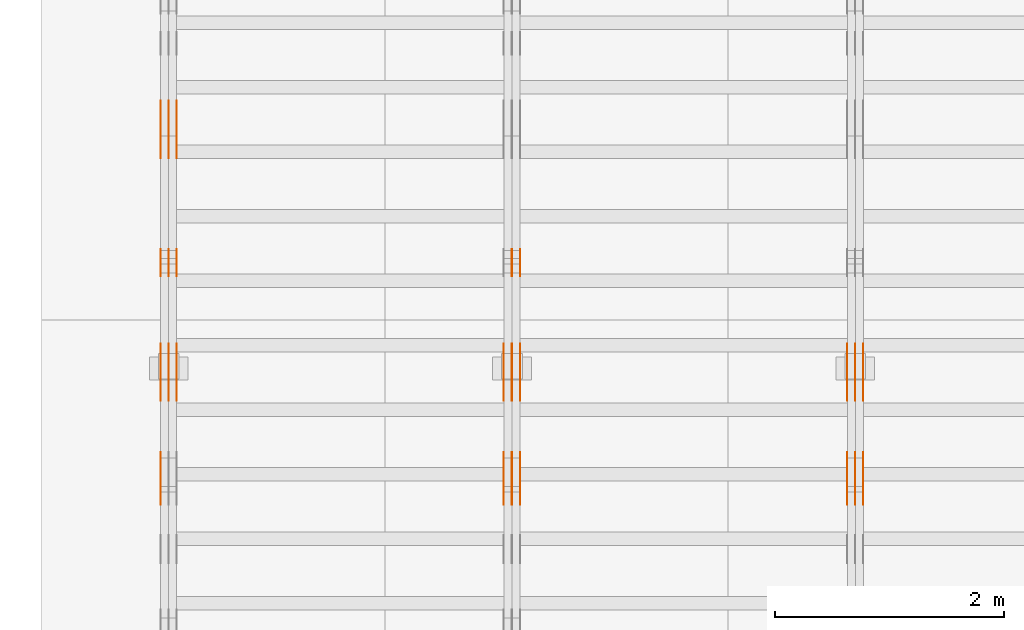
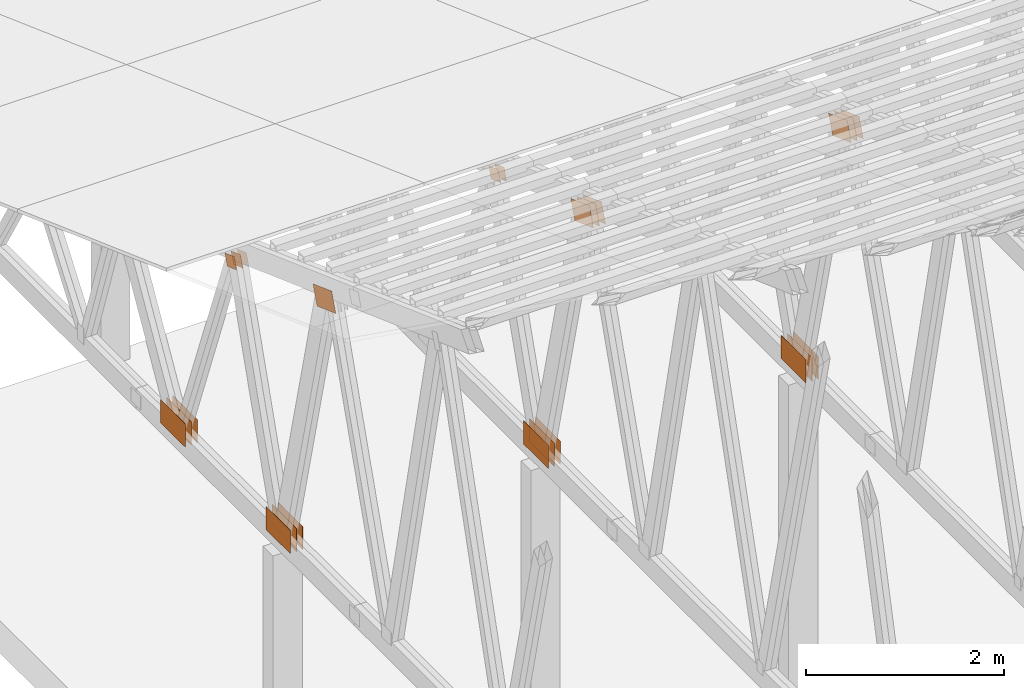
# One storey, part 107 of 189: 31 proxies.
"""IFC2X3 building model written with IfcOpenShell, lengths in millimetres."""

from ifc_helpers import new_model, entity, si_unit, converted_unit, derived_unit, direction, frame, origin, origin_2d_with_axis, place, context, subcontext, project, spatial, polyline, rectangle, outline, extrude, source, transform, mapped, material, type_object, type_shapes, element, save


model = new_model("IFC2X3")

# Units and contexts
model_context = context("Model", 3, precision=0.01, world=origin(), true_north=direction((6.12303176911189e-17, 1.0)))
body_context = subcontext(model_context, "Body", "Model", "MODEL_VIEW")
ifc_project = project(units=[si_unit("LENGTHUNIT", "METRE", prefix="MILLI"), si_unit("AREAUNIT", "SQUARE_METRE"), si_unit("VOLUMEUNIT", "CUBIC_METRE"), converted_unit("PLANEANGLEUNIT", "DEGREE", entity("IfcRatioMeasure", 0.0174532925199433), si_unit("PLANEANGLEUNIT", "RADIAN"), dimensions=[0, 0, 0, 0, 0, 0, 0]), si_unit("MASSUNIT", "GRAM", prefix="KILO"), derived_unit("MASSDENSITYUNIT", [(si_unit("MASSUNIT", "GRAM", prefix="KILO"), 1), (si_unit("LENGTHUNIT", "METRE"), -3)]), si_unit("TIMEUNIT", "SECOND"), si_unit("FREQUENCYUNIT", "HERTZ"), si_unit("THERMODYNAMICTEMPERATUREUNIT", "DEGREE_CELSIUS"), derived_unit("THERMALTRANSMITTANCEUNIT", [(si_unit("MASSUNIT", "GRAM", prefix="KILO"), 1), (si_unit("THERMODYNAMICTEMPERATUREUNIT", "KELVIN"), -1), (si_unit("TIMEUNIT", "SECOND"), -3)]), derived_unit("VOLUMETRICFLOWRATEUNIT", [(si_unit("LENGTHUNIT", "METRE"), 3), (si_unit("TIMEUNIT", "SECOND"), -1)]), si_unit("ELECTRICCURRENTUNIT", "AMPERE"), si_unit("ELECTRICVOLTAGEUNIT", "VOLT"), si_unit("POWERUNIT", "WATT"), si_unit("FORCEUNIT", "NEWTON"), si_unit("ILLUMINANCEUNIT", "LUX"), si_unit("LUMINOUSFLUXUNIT", "LUMEN"), si_unit("LUMINOUSINTENSITYUNIT", "CANDELA"), derived_unit("USERDEFINED", [(si_unit("MASSUNIT", "GRAM", prefix="KILO"), -1), (si_unit("LENGTHUNIT", "METRE"), -2), (si_unit("TIMEUNIT", "SECOND"), 3), (si_unit("LUMINOUSFLUXUNIT", "LUMEN"), 1)]), derived_unit("LINEARVELOCITYUNIT", [(si_unit("LENGTHUNIT", "METRE"), 1), (si_unit("TIMEUNIT", "SECOND"), -1)]), si_unit("PRESSUREUNIT", "PASCAL"), derived_unit("USERDEFINED", [(si_unit("LENGTHUNIT", "METRE"), -2), (si_unit("MASSUNIT", "GRAM", prefix="KILO"), 1), (si_unit("TIMEUNIT", "SECOND"), -2)])], contexts=[model_context])

# Site, building, storey
site_placement = place(None, origin())
site = spatial("IfcSite", under=ifc_project, at=site_placement, CompositionType="ELEMENT")
building_placement = place(site_placement, origin())
building = spatial("IfcBuilding", under=site, at=building_placement, CompositionType="ELEMENT")
storey_placement = place(building_placement, origin())
storey = spatial("IfcBuildingStorey", under=building, at=storey_placement, Name="Default", CompositionType="ELEMENT", Elevation=0.0)

# Proxies
ifc_material_1 = material(Name="IfcSurfaceStyle #44914")
building_element_proxy_type_1 = type_object("IfcBuildingElementProxyType", PredefinedType="NOTDEFINED", material=ifc_material_1)
shared_shape_1 = source(origin(), body_context, "Body", "SweptSolid", [
    extrude(outline(polyline([(-200.000344770935, -119.999765965113), (199.999582244654, -119.999765965113), (200.000344770935, 119.999765965113), (-199.999582244653, 119.999765965113), (-200.000344770935, -119.999765965113)])), frame((200.000344770935, 119.999990805307, 0.0), z_axis=(0.0, 0.0, 1.0), x_axis=(-1.0, 0.0, 0.0)), (0.0, 0.0, 1.0), 1.29999999999999),
])
type_shapes(building_element_proxy_type_1, [shared_shape_1])
proxy_1_placement = place(building_placement, frame((6336.3, 19620.1777846684, 3837.77137841443), z_axis=(-1.0, 0.0, 0.0), x_axis=(0.0, 0.939692620785908, -0.342020143325669)))
element("IfcBuildingElementProxy", 1, at=proxy_1_placement, inside=storey, type_object=building_element_proxy_type_1, material=ifc_material_1, context=body_context, shape_type="MappedRepresentation", body=[
    mapped(shared_shape_1, transform((0.0, 0.0, 0.0), scale=1.0)),
])
ifc_material_2 = material(Name="IfcSurfaceStyle #44857")
building_element_proxy_type_2 = type_object("IfcBuildingElementProxyType", PredefinedType="NOTDEFINED", material=ifc_material_2)
shared_shape_2 = source(origin(), body_context, "Body", "SweptSolid", [
    extrude(outline(polyline([(-200.000344770935, -119.999765965113), (199.999582244654, -119.999765965113), (200.000344770935, 119.999765965113), (-199.999582244653, 119.999765965113), (-200.000344770935, -119.999765965113)])), frame((200.000344770935, 119.999990805307, 0.0), z_axis=(0.0, 0.0, 1.0), x_axis=(-1.0, 0.0, 0.0)), (0.0, 0.0, 1.0), 1.29999999999997),
])
type_shapes(building_element_proxy_type_2, [shared_shape_2])
proxy_2_placement = place(building_placement, frame((6265.0, 19620.1777846684, 3837.77137841443), z_axis=(-1.0, 0.0, 0.0), x_axis=(0.0, 0.939692620785908, -0.342020143325669)))
element("IfcBuildingElementProxy", 2, at=proxy_2_placement, inside=storey, type_object=building_element_proxy_type_2, material=ifc_material_2, context=body_context, shape_type="MappedRepresentation", body=[
    mapped(shared_shape_2, transform((0.0, 0.0, 0.0), scale=1.0)),
])
ifc_material_3 = material(Name="IfcSurfaceStyle #44800")
building_element_proxy_type_3 = type_object("IfcBuildingElementProxyType", PredefinedType="NOTDEFINED", material=ifc_material_3)
shared_shape_3 = source(origin(), body_context, "Body", "SweptSolid", [
    extrude(outline(polyline([(-200.000344770935, -119.999765965113), (199.999582244654, -119.999765965113), (200.000344770935, 119.999765965113), (-199.999582244653, 119.999765965113), (-200.000344770935, -119.999765965113)])), frame((200.000344770935, 119.999990805307, 0.0), z_axis=(0.0, 0.0, 1.0), x_axis=(-1.0, 0.0, 0.0)), (0.0, 0.0, 1.0), 1.29999999999997),
])
type_shapes(building_element_proxy_type_3, [shared_shape_3])
proxy_3_placement = place(building_placement, frame((6266.3, 19620.1777846684, 3837.77137841443), z_axis=(-1.0, 0.0, 0.0), x_axis=(0.0, 0.939692620785908, -0.342020143325669)))
element("IfcBuildingElementProxy", 3, at=proxy_3_placement, inside=storey, type_object=building_element_proxy_type_3, material=ifc_material_3, context=body_context, shape_type="MappedRepresentation", body=[
    mapped(shared_shape_3, transform((0.0, 0.0, 0.0), scale=1.0)),
])
ifc_material_4 = material(Name="IfcSurfaceStyle #44743")
building_element_proxy_type_4 = type_object("IfcBuildingElementProxyType", PredefinedType="NOTDEFINED", material=ifc_material_4)
shared_shape_4 = source(origin(), body_context, "Body", "SweptSolid", [
    extrude(outline(polyline([(-200.000344770935, -119.999765965113), (199.999582244654, -119.999765965113), (200.000344770935, 119.999765965113), (-199.999582244653, 119.999765965113), (-200.000344770935, -119.999765965113)])), frame((200.000344770935, 119.999990805307, 0.0), z_axis=(0.0, 0.0, 1.0), x_axis=(-1.0, 0.0, 0.0)), (0.0, 0.0, 1.0), 1.29999999999998),
])
type_shapes(building_element_proxy_type_4, [shared_shape_4])
proxy_4_placement = place(building_placement, frame((6195.0, 19620.1777846684, 3837.77137841443), z_axis=(-1.0, 0.0, 0.0), x_axis=(0.0, 0.939692620785908, -0.342020143325669)))
element("IfcBuildingElementProxy", 4, at=proxy_4_placement, inside=storey, type_object=building_element_proxy_type_4, material=ifc_material_4, context=body_context, shape_type="MappedRepresentation", body=[
    mapped(shared_shape_4, transform((0.0, 0.0, 0.0), scale=1.0)),
])
ifc_material_5 = material(Name="IfcSurfaceStyle #44686")
building_element_proxy_type_5 = type_object("IfcBuildingElementProxyType", PredefinedType="NOTDEFINED", material=ifc_material_5)
shared_shape_5 = source(origin(), body_context, "Body", "SweptSolid", [
    extrude(rectangle(XDim=500.0, YDim=288.0, at=origin_2d_with_axis()), frame((250.0, 144.0, 0.0), z_axis=(0.0, 0.0, 1.0), x_axis=(-1.0, 0.0, 0.0)), (0.0, 0.0, 1.0), 1.29999999999998),
])
type_shapes(building_element_proxy_type_5, [shared_shape_5])
proxy_5_placement = place(building_placement, frame((6336.3, 20948.0908203125, 101.0), z_axis=(-1.0, 0.0, 0.0), x_axis=(0.0, -1.0, 0.0)))
element("IfcBuildingElementProxy", 5, at=proxy_5_placement, inside=storey, type_object=building_element_proxy_type_5, material=ifc_material_5, context=body_context, shape_type="MappedRepresentation", body=[
    mapped(shared_shape_5, transform((0.0, 0.0, 0.0), scale=1.0)),
])
ifc_material_6 = material(Name="IfcSurfaceStyle #44629")
building_element_proxy_type_6 = type_object("IfcBuildingElementProxyType", PredefinedType="NOTDEFINED", material=ifc_material_6)
shared_shape_6 = source(origin(), body_context, "Body", "SweptSolid", [
    extrude(rectangle(XDim=500.0, YDim=288.0, at=origin_2d_with_axis()), frame((250.0, 144.0, 0.0), z_axis=(0.0, 0.0, 1.0), x_axis=(-1.0, 0.0, 0.0)), (0.0, 0.0, 1.0), 1.29999999999997),
])
type_shapes(building_element_proxy_type_6, [shared_shape_6])
proxy_6_placement = place(building_placement, frame((6265.0, 20948.0908203125, 101.0), z_axis=(-1.0, 0.0, 0.0), x_axis=(0.0, -1.0, 0.0)))
element("IfcBuildingElementProxy", 6, at=proxy_6_placement, inside=storey, type_object=building_element_proxy_type_6, material=ifc_material_6, context=body_context, shape_type="MappedRepresentation", body=[
    mapped(shared_shape_6, transform((0.0, 0.0, 0.0), scale=1.0)),
])
ifc_material_7 = material(Name="IfcSurfaceStyle #44572")
building_element_proxy_type_7 = type_object("IfcBuildingElementProxyType", PredefinedType="NOTDEFINED", material=ifc_material_7)
shared_shape_7 = source(origin(), body_context, "Body", "SweptSolid", [
    extrude(rectangle(XDim=500.0, YDim=288.0, at=origin_2d_with_axis()), frame((250.0, 144.0, 0.0), z_axis=(0.0, 0.0, 1.0), x_axis=(-1.0, 0.0, 0.0)), (0.0, 0.0, 1.0), 1.29999999999997),
])
type_shapes(building_element_proxy_type_7, [shared_shape_7])
proxy_7_placement = place(building_placement, frame((6266.3, 20948.0908203125, 101.0), z_axis=(-1.0, 0.0, 0.0), x_axis=(0.0, -1.0, 0.0)))
element("IfcBuildingElementProxy", 7, at=proxy_7_placement, inside=storey, type_object=building_element_proxy_type_7, material=ifc_material_7, context=body_context, shape_type="MappedRepresentation", body=[
    mapped(shared_shape_7, transform((0.0, 0.0, 0.0), scale=1.0)),
])
ifc_material_8 = material(Name="IfcSurfaceStyle #44515")
building_element_proxy_type_8 = type_object("IfcBuildingElementProxyType", PredefinedType="NOTDEFINED", material=ifc_material_8)
shared_shape_8 = source(origin(), body_context, "Body", "SweptSolid", [
    extrude(rectangle(XDim=500.0, YDim=288.0, at=origin_2d_with_axis()), frame((250.0, 144.0, 0.0), z_axis=(0.0, 0.0, 1.0), x_axis=(-1.0, 0.0, 0.0)), (0.0, 0.0, 1.0), 1.29999999999997),
])
type_shapes(building_element_proxy_type_8, [shared_shape_8])
proxy_8_placement = place(building_placement, frame((6195.0, 20948.0908203125, 101.0), z_axis=(-1.0, 0.0, 0.0), x_axis=(0.0, -1.0, 0.0)))
element("IfcBuildingElementProxy", 8, at=proxy_8_placement, inside=storey, type_object=building_element_proxy_type_8, material=ifc_material_8, context=body_context, shape_type="MappedRepresentation", body=[
    mapped(shared_shape_8, transform((0.0, 0.0, 0.0), scale=1.0)),
])
ifc_material_9 = material(Name="IfcSurfaceStyle #29124")
building_element_proxy_type_9 = type_object("IfcBuildingElementProxyType", PredefinedType="NOTDEFINED", material=ifc_material_9)
shared_shape_9 = source(origin(), body_context, "Body", "SweptSolid", [
    extrude(outline(polyline([(-200.000344770935, -119.999765965113), (199.999582244654, -119.999765965113), (200.000344770935, 119.999765965113), (-199.999582244653, 119.999765965113), (-200.000344770935, -119.999765965113)])), frame((200.000344770935, 119.999990805307, 0.0), z_axis=(0.0, 0.0, 1.0), x_axis=(-1.0, 0.0, 0.0)), (0.0, 0.0, 1.0), 1.29999999999999),
])
type_shapes(building_element_proxy_type_9, [shared_shape_9])
proxy_9_placement = place(building_placement, frame((3336.3, 19620.1777846684, 3837.77137841443), z_axis=(-1.0, 0.0, 0.0), x_axis=(0.0, 0.939692620785908, -0.342020143325669)))
element("IfcBuildingElementProxy", 9, at=proxy_9_placement, inside=storey, type_object=building_element_proxy_type_9, material=ifc_material_9, context=body_context, shape_type="MappedRepresentation", body=[
    mapped(shared_shape_9, transform((0.0, 0.0, 0.0), scale=1.0)),
])
ifc_material_10 = material(Name="IfcSurfaceStyle #29067")
building_element_proxy_type_10 = type_object("IfcBuildingElementProxyType", PredefinedType="NOTDEFINED", material=ifc_material_10)
shared_shape_10 = source(origin(), body_context, "Body", "SweptSolid", [
    extrude(outline(polyline([(-200.000344770935, -119.999765965113), (199.999582244654, -119.999765965113), (200.000344770935, 119.999765965113), (-199.999582244653, 119.999765965113), (-200.000344770935, -119.999765965113)])), frame((200.000344770935, 119.999990805307, 0.0), z_axis=(0.0, 0.0, 1.0), x_axis=(-1.0, 0.0, 0.0)), (0.0, 0.0, 1.0), 1.29999999999997),
])
type_shapes(building_element_proxy_type_10, [shared_shape_10])
proxy_10_placement = place(building_placement, frame((3265.0, 19620.1777846684, 3837.77137841443), z_axis=(-1.0, 0.0, 0.0), x_axis=(0.0, 0.939692620785908, -0.342020143325669)))
element("IfcBuildingElementProxy", 10, at=proxy_10_placement, inside=storey, type_object=building_element_proxy_type_10, material=ifc_material_10, context=body_context, shape_type="MappedRepresentation", body=[
    mapped(shared_shape_10, transform((0.0, 0.0, 0.0), scale=1.0)),
])
ifc_material_11 = material(Name="IfcSurfaceStyle #29010")
building_element_proxy_type_11 = type_object("IfcBuildingElementProxyType", PredefinedType="NOTDEFINED", material=ifc_material_11)
shared_shape_11 = source(origin(), body_context, "Body", "SweptSolid", [
    extrude(outline(polyline([(-200.000344770935, -119.999765965113), (199.999582244654, -119.999765965113), (200.000344770935, 119.999765965113), (-199.999582244653, 119.999765965113), (-200.000344770935, -119.999765965113)])), frame((200.000344770935, 119.999990805307, 0.0), z_axis=(0.0, 0.0, 1.0), x_axis=(-1.0, 0.0, 0.0)), (0.0, 0.0, 1.0), 1.29999999999997),
])
type_shapes(building_element_proxy_type_11, [shared_shape_11])
proxy_11_placement = place(building_placement, frame((3266.3, 19620.1777846684, 3837.77137841443), z_axis=(-1.0, 0.0, 0.0), x_axis=(0.0, 0.939692620785908, -0.342020143325669)))
element("IfcBuildingElementProxy", 11, at=proxy_11_placement, inside=storey, type_object=building_element_proxy_type_11, material=ifc_material_11, context=body_context, shape_type="MappedRepresentation", body=[
    mapped(shared_shape_11, transform((0.0, 0.0, 0.0), scale=1.0)),
])
ifc_material_12 = material(Name="IfcSurfaceStyle #28953")
building_element_proxy_type_12 = type_object("IfcBuildingElementProxyType", PredefinedType="NOTDEFINED", material=ifc_material_12)
shared_shape_12 = source(origin(), body_context, "Body", "SweptSolid", [
    extrude(outline(polyline([(-200.000344770935, -119.999765965113), (199.999582244654, -119.999765965113), (200.000344770935, 119.999765965113), (-199.999582244653, 119.999765965113), (-200.000344770935, -119.999765965113)])), frame((200.000344770935, 119.999990805307, 0.0), z_axis=(0.0, 0.0, 1.0), x_axis=(-1.0, 0.0, 0.0)), (0.0, 0.0, 1.0), 1.29999999999998),
])
type_shapes(building_element_proxy_type_12, [shared_shape_12])
proxy_12_placement = place(building_placement, frame((3195.0, 19620.1777846684, 3837.77137841443), z_axis=(-1.0, 0.0, 0.0), x_axis=(0.0, 0.939692620785908, -0.342020143325669)))
element("IfcBuildingElementProxy", 12, at=proxy_12_placement, inside=storey, type_object=building_element_proxy_type_12, material=ifc_material_12, context=body_context, shape_type="MappedRepresentation", body=[
    mapped(shared_shape_12, transform((0.0, 0.0, 0.0), scale=1.0)),
])
ifc_material_13 = material(Name="IfcSurfaceStyle #28896")
building_element_proxy_type_13 = type_object("IfcBuildingElementProxyType", PredefinedType="NOTDEFINED", material=ifc_material_13)
shared_shape_13 = source(origin(), body_context, "Body", "SweptSolid", [
    extrude(rectangle(XDim=500.0, YDim=288.0, at=origin_2d_with_axis()), frame((250.0, 144.0, 0.0), z_axis=(0.0, 0.0, 1.0), x_axis=(-1.0, 0.0, 0.0)), (0.0, 0.0, 1.0), 1.29999999999998),
])
type_shapes(building_element_proxy_type_13, [shared_shape_13])
proxy_13_placement = place(building_placement, frame((3336.3, 20948.0908203125, 101.0), z_axis=(-1.0, 0.0, 0.0), x_axis=(0.0, -1.0, 0.0)))
element("IfcBuildingElementProxy", 13, at=proxy_13_placement, inside=storey, type_object=building_element_proxy_type_13, material=ifc_material_13, context=body_context, shape_type="MappedRepresentation", body=[
    mapped(shared_shape_13, transform((0.0, 0.0, 0.0), scale=1.0)),
])
ifc_material_14 = material(Name="IfcSurfaceStyle #28839")
building_element_proxy_type_14 = type_object("IfcBuildingElementProxyType", PredefinedType="NOTDEFINED", material=ifc_material_14)
shared_shape_14 = source(origin(), body_context, "Body", "SweptSolid", [
    extrude(rectangle(XDim=500.0, YDim=288.0, at=origin_2d_with_axis()), frame((250.0, 144.0, 0.0), z_axis=(0.0, 0.0, 1.0), x_axis=(-1.0, 0.0, 0.0)), (0.0, 0.0, 1.0), 1.29999999999997),
])
type_shapes(building_element_proxy_type_14, [shared_shape_14])
proxy_14_placement = place(building_placement, frame((3265.0, 20948.0908203125, 101.0), z_axis=(-1.0, 0.0, 0.0), x_axis=(0.0, -1.0, 0.0)))
element("IfcBuildingElementProxy", 14, at=proxy_14_placement, inside=storey, type_object=building_element_proxy_type_14, material=ifc_material_14, context=body_context, shape_type="MappedRepresentation", body=[
    mapped(shared_shape_14, transform((0.0, 0.0, 0.0), scale=1.0)),
])
ifc_material_15 = material(Name="IfcSurfaceStyle #28782")
building_element_proxy_type_15 = type_object("IfcBuildingElementProxyType", PredefinedType="NOTDEFINED", material=ifc_material_15)
shared_shape_15 = source(origin(), body_context, "Body", "SweptSolid", [
    extrude(rectangle(XDim=500.0, YDim=288.0, at=origin_2d_with_axis()), frame((250.0, 144.0, 0.0), z_axis=(0.0, 0.0, 1.0), x_axis=(-1.0, 0.0, 0.0)), (0.0, 0.0, 1.0), 1.29999999999997),
])
type_shapes(building_element_proxy_type_15, [shared_shape_15])
proxy_15_placement = place(building_placement, frame((3266.3, 20948.0908203125, 101.0), z_axis=(-1.0, 0.0, 0.0), x_axis=(0.0, -1.0, 0.0)))
element("IfcBuildingElementProxy", 15, at=proxy_15_placement, inside=storey, type_object=building_element_proxy_type_15, material=ifc_material_15, context=body_context, shape_type="MappedRepresentation", body=[
    mapped(shared_shape_15, transform((0.0, 0.0, 0.0), scale=1.0)),
])
ifc_material_16 = material(Name="IfcSurfaceStyle #28725")
building_element_proxy_type_16 = type_object("IfcBuildingElementProxyType", PredefinedType="NOTDEFINED", material=ifc_material_16)
shared_shape_16 = source(origin(), body_context, "Body", "SweptSolid", [
    extrude(rectangle(XDim=500.0, YDim=288.0, at=origin_2d_with_axis()), frame((250.0, 144.0, 0.0), z_axis=(0.0, 0.0, 1.0), x_axis=(-1.0, 0.0, 0.0)), (0.0, 0.0, 1.0), 1.29999999999997),
])
type_shapes(building_element_proxy_type_16, [shared_shape_16])
proxy_16_placement = place(building_placement, frame((3195.0, 20948.0908203125, 101.0), z_axis=(-1.0, 0.0, 0.0), x_axis=(0.0, -1.0, 0.0)))
element("IfcBuildingElementProxy", 16, at=proxy_16_placement, inside=storey, type_object=building_element_proxy_type_16, material=ifc_material_16, context=body_context, shape_type="MappedRepresentation", body=[
    mapped(shared_shape_16, transform((0.0, 0.0, 0.0), scale=1.0)),
])
ifc_material_17 = material(Name="IfcSurfaceStyle #28212")
building_element_proxy_type_17 = type_object("IfcBuildingElementProxyType", PredefinedType="NOTDEFINED", material=ifc_material_17)
shared_shape_17 = source(origin(), body_context, "Body", "SweptSolid", [
    extrude(outline(polyline([(-100.000279336925, -71.9999636698844), (100.000143005157, -71.9999636698844), (100.00004991978, 71.9999636698844), (-99.9999135880125, 71.9999636698845), (-100.000279336925, -71.9999636698844)])), frame((100.000143005157, 72.0001110824169, 0.0), z_axis=(0.0, 0.0, 1.0), x_axis=(-1.0, 0.0, 0.0)), (0.0, 0.0, 1.0), 1.3),
])
type_shapes(building_element_proxy_type_17, [shared_shape_17])
proxy_17_placement = place(building_placement, frame((3336.3, 21584.0819808932, 3071.51551466861), z_axis=(-1.0, 0.0, 0.0), x_axis=(0.0, 0.939692620785908, -0.342020143325669)))
element("IfcBuildingElementProxy", 17, at=proxy_17_placement, inside=storey, type_object=building_element_proxy_type_17, material=ifc_material_17, context=body_context, shape_type="MappedRepresentation", body=[
    mapped(shared_shape_17, transform((0.0, 0.0, 0.0), scale=1.0)),
])
ifc_material_18 = material(Name="IfcSurfaceStyle #28155")
building_element_proxy_type_18 = type_object("IfcBuildingElementProxyType", PredefinedType="NOTDEFINED", material=ifc_material_18)
shared_shape_18 = source(origin(), body_context, "Body", "SweptSolid", [
    extrude(outline(polyline([(-100.000279336925, -71.9999636698844), (100.000143005157, -71.9999636698844), (100.00004991978, 71.9999636698844), (-99.9999135880125, 71.9999636698845), (-100.000279336925, -71.9999636698844)])), frame((100.000143005157, 72.0001110824169, 0.0), z_axis=(0.0, 0.0, 1.0), x_axis=(-1.0, 0.0, 0.0)), (0.0, 0.0, 1.0), 1.29999999999998),
])
type_shapes(building_element_proxy_type_18, [shared_shape_18])
proxy_18_placement = place(building_placement, frame((3265.0, 21584.0819808932, 3071.51551466861), z_axis=(-1.0, 0.0, 0.0), x_axis=(0.0, 0.939692620785908, -0.342020143325669)))
element("IfcBuildingElementProxy", 18, at=proxy_18_placement, inside=storey, type_object=building_element_proxy_type_18, material=ifc_material_18, context=body_context, shape_type="MappedRepresentation", body=[
    mapped(shared_shape_18, transform((0.0, 0.0, 0.0), scale=1.0)),
])
ifc_material_19 = material(Name="IfcSurfaceStyle #13160")
building_element_proxy_type_19 = type_object("IfcBuildingElementProxyType", PredefinedType="NOTDEFINED", material=ifc_material_19)
shared_shape_19 = source(origin(), body_context, "Body", "SweptSolid", [
    extrude(outline(polyline([(-200.000344770935, -119.999765965113), (199.999582244654, -119.999765965113), (200.000344770935, 119.999765965113), (-199.999582244653, 119.999765965113), (-200.000344770935, -119.999765965113)])), frame((200.000344770935, 119.999990805307, 0.0), z_axis=(0.0, 0.0, 1.0), x_axis=(-1.0, 0.0, 0.0)), (0.0, 0.0, 1.0), 1.29999999999998),
])
type_shapes(building_element_proxy_type_19, [shared_shape_19])
proxy_19_placement = place(building_placement, frame((195.0, 19620.1777846684, 3837.77137841443), z_axis=(-1.0, 0.0, 0.0), x_axis=(0.0, 0.939692620785908, -0.342020143325669)))
element("IfcBuildingElementProxy", 19, at=proxy_19_placement, inside=storey, type_object=building_element_proxy_type_19, material=ifc_material_19, context=body_context, shape_type="MappedRepresentation", body=[
    mapped(shared_shape_19, transform((0.0, 0.0, 0.0), scale=1.0)),
])
ifc_material_20 = material(Name="IfcSurfaceStyle #13103")
building_element_proxy_type_20 = type_object("IfcBuildingElementProxyType", PredefinedType="NOTDEFINED", material=ifc_material_20)
shared_shape_20 = source(origin(), body_context, "Body", "SweptSolid", [
    extrude(rectangle(XDim=500.0, YDim=288.0, at=origin_2d_with_axis()), frame((250.0, 144.0, 0.0), z_axis=(0.0, 0.0, 1.0), x_axis=(-1.0, 0.0, 0.0)), (0.0, 0.0, 1.0), 1.29999999999998),
])
type_shapes(building_element_proxy_type_20, [shared_shape_20])
proxy_20_placement = place(building_placement, frame((336.3, 20948.0908203125, 101.0), z_axis=(-1.0, 0.0, 0.0), x_axis=(0.0, -1.0, 0.0)))
element("IfcBuildingElementProxy", 20, at=proxy_20_placement, inside=storey, type_object=building_element_proxy_type_20, material=ifc_material_20, context=body_context, shape_type="MappedRepresentation", body=[
    mapped(shared_shape_20, transform((0.0, 0.0, 0.0), scale=1.0)),
])
ifc_material_21 = material(Name="IfcSurfaceStyle #13046")
building_element_proxy_type_21 = type_object("IfcBuildingElementProxyType", PredefinedType="NOTDEFINED", material=ifc_material_21)
shared_shape_21 = source(origin(), body_context, "Body", "SweptSolid", [
    extrude(rectangle(XDim=500.0, YDim=288.0, at=origin_2d_with_axis()), frame((250.0, 144.0, 0.0), z_axis=(0.0, 0.0, 1.0), x_axis=(-1.0, 0.0, 0.0)), (0.0, 0.0, 1.0), 1.29999999999997),
])
type_shapes(building_element_proxy_type_21, [shared_shape_21])
proxy_21_placement = place(building_placement, frame((265.0, 20948.0908203125, 101.0), z_axis=(-1.0, 0.0, 0.0), x_axis=(0.0, -1.0, 0.0)))
element("IfcBuildingElementProxy", 21, at=proxy_21_placement, inside=storey, type_object=building_element_proxy_type_21, material=ifc_material_21, context=body_context, shape_type="MappedRepresentation", body=[
    mapped(shared_shape_21, transform((0.0, 0.0, 0.0), scale=1.0)),
])
ifc_material_22 = material(Name="IfcSurfaceStyle #12989")
building_element_proxy_type_22 = type_object("IfcBuildingElementProxyType", PredefinedType="NOTDEFINED", material=ifc_material_22)
shared_shape_22 = source(origin(), body_context, "Body", "SweptSolid", [
    extrude(rectangle(XDim=500.0, YDim=288.0, at=origin_2d_with_axis()), frame((250.0, 144.0, 0.0), z_axis=(0.0, 0.0, 1.0), x_axis=(-1.0, 0.0, 0.0)), (0.0, 0.0, 1.0), 1.29999999999997),
])
type_shapes(building_element_proxy_type_22, [shared_shape_22])
proxy_22_placement = place(building_placement, frame((266.3, 20948.0908203125, 101.0), z_axis=(-1.0, 0.0, 0.0), x_axis=(0.0, -1.0, 0.0)))
element("IfcBuildingElementProxy", 22, at=proxy_22_placement, inside=storey, type_object=building_element_proxy_type_22, material=ifc_material_22, context=body_context, shape_type="MappedRepresentation", body=[
    mapped(shared_shape_22, transform((0.0, 0.0, 0.0), scale=1.0)),
])
ifc_material_23 = material(Name="IfcSurfaceStyle #12932")
building_element_proxy_type_23 = type_object("IfcBuildingElementProxyType", PredefinedType="NOTDEFINED", material=ifc_material_23)
shared_shape_23 = source(origin(), body_context, "Body", "SweptSolid", [
    extrude(rectangle(XDim=500.0, YDim=288.0, at=origin_2d_with_axis()), frame((250.0, 144.0, 0.0), z_axis=(0.0, 0.0, 1.0), x_axis=(-1.0, 0.0, 0.0)), (0.0, 0.0, 1.0), 1.29999999999997),
])
type_shapes(building_element_proxy_type_23, [shared_shape_23])
proxy_23_placement = place(building_placement, frame((195.0, 20948.0908203125, 101.0), z_axis=(-1.0, 0.0, 0.0), x_axis=(0.0, -1.0, 0.0)))
element("IfcBuildingElementProxy", 23, at=proxy_23_placement, inside=storey, type_object=building_element_proxy_type_23, material=ifc_material_23, context=body_context, shape_type="MappedRepresentation", body=[
    mapped(shared_shape_23, transform((0.0, 0.0, 0.0), scale=1.0)),
])
ifc_material_24 = material(Name="IfcSurfaceStyle #12419")
building_element_proxy_type_24 = type_object("IfcBuildingElementProxyType", PredefinedType="NOTDEFINED", material=ifc_material_24)
shared_shape_24 = source(origin(), body_context, "Body", "SweptSolid", [
    extrude(outline(polyline([(-100.000279336925, -71.9999636698844), (100.000143005157, -71.9999636698844), (100.00004991978, 71.9999636698844), (-99.9999135880125, 71.9999636698845), (-100.000279336925, -71.9999636698844)])), frame((100.000143005157, 72.0001110824169, 0.0), z_axis=(0.0, 0.0, 1.0), x_axis=(-1.0, 0.0, 0.0)), (0.0, 0.0, 1.0), 1.3),
])
type_shapes(building_element_proxy_type_24, [shared_shape_24])
proxy_24_placement = place(building_placement, frame((336.3, 21584.0819808932, 3071.51551466861), z_axis=(-1.0, 0.0, 0.0), x_axis=(0.0, 0.939692620785908, -0.342020143325669)))
element("IfcBuildingElementProxy", 24, at=proxy_24_placement, inside=storey, type_object=building_element_proxy_type_24, material=ifc_material_24, context=body_context, shape_type="MappedRepresentation", body=[
    mapped(shared_shape_24, transform((0.0, 0.0, 0.0), scale=1.0)),
])
ifc_material_25 = material(Name="IfcSurfaceStyle #12362")
building_element_proxy_type_25 = type_object("IfcBuildingElementProxyType", PredefinedType="NOTDEFINED", material=ifc_material_25)
shared_shape_25 = source(origin(), body_context, "Body", "SweptSolid", [
    extrude(outline(polyline([(-100.000279336925, -71.9999636698844), (100.000143005157, -71.9999636698844), (100.00004991978, 71.9999636698844), (-99.9999135880125, 71.9999636698845), (-100.000279336925, -71.9999636698844)])), frame((100.000143005157, 72.0001110824169, 0.0), z_axis=(0.0, 0.0, 1.0), x_axis=(-1.0, 0.0, 0.0)), (0.0, 0.0, 1.0), 1.29999999999998),
])
type_shapes(building_element_proxy_type_25, [shared_shape_25])
proxy_25_placement = place(building_placement, frame((265.0, 21584.0819808932, 3071.51551466861), z_axis=(-1.0, 0.0, 0.0), x_axis=(0.0, 0.939692620785908, -0.342020143325669)))
element("IfcBuildingElementProxy", 25, at=proxy_25_placement, inside=storey, type_object=building_element_proxy_type_25, material=ifc_material_25, context=body_context, shape_type="MappedRepresentation", body=[
    mapped(shared_shape_25, transform((0.0, 0.0, 0.0), scale=1.0)),
])
ifc_material_26 = material(Name="IfcSurfaceStyle #12305")
building_element_proxy_type_26 = type_object("IfcBuildingElementProxyType", PredefinedType="NOTDEFINED", material=ifc_material_26)
shared_shape_26 = source(origin(), body_context, "Body", "SweptSolid", [
    extrude(outline(polyline([(-100.000279336925, -71.9999636698844), (100.000143005157, -71.9999636698844), (100.00004991978, 71.9999636698844), (-99.9999135880125, 71.9999636698845), (-100.000279336925, -71.9999636698844)])), frame((100.000143005157, 72.0001110824169, 0.0), z_axis=(0.0, 0.0, 1.0), x_axis=(-1.0, 0.0, 0.0)), (0.0, 0.0, 1.0), 1.29999999999998),
])
type_shapes(building_element_proxy_type_26, [shared_shape_26])
proxy_26_placement = place(building_placement, frame((266.3, 21584.0819808932, 3071.51551466861), z_axis=(-1.0, 0.0, 0.0), x_axis=(0.0, 0.939692620785908, -0.342020143325669)))
element("IfcBuildingElementProxy", 26, at=proxy_26_placement, inside=storey, type_object=building_element_proxy_type_26, material=ifc_material_26, context=body_context, shape_type="MappedRepresentation", body=[
    mapped(shared_shape_26, transform((0.0, 0.0, 0.0), scale=1.0)),
])
ifc_material_27 = material(Name="IfcSurfaceStyle #12248")
building_element_proxy_type_27 = type_object("IfcBuildingElementProxyType", PredefinedType="NOTDEFINED", material=ifc_material_27)
shared_shape_27 = source(origin(), body_context, "Body", "SweptSolid", [
    extrude(outline(polyline([(-100.000279336925, -71.9999636698844), (100.000143005157, -71.9999636698844), (100.00004991978, 71.9999636698844), (-99.9999135880125, 71.9999636698845), (-100.000279336925, -71.9999636698844)])), frame((100.000143005157, 72.0001110824169, 0.0), z_axis=(0.0, 0.0, 1.0), x_axis=(-1.0, 0.0, 0.0)), (0.0, 0.0, 1.0), 1.29999999999999),
])
type_shapes(building_element_proxy_type_27, [shared_shape_27])
proxy_27_placement = place(building_placement, frame((195.0, 21584.0819808932, 3071.51551466861), z_axis=(-1.0, 0.0, 0.0), x_axis=(0.0, 0.939692620785908, -0.342020143325669)))
element("IfcBuildingElementProxy", 27, at=proxy_27_placement, inside=storey, type_object=building_element_proxy_type_27, material=ifc_material_27, context=body_context, shape_type="MappedRepresentation", body=[
    mapped(shared_shape_27, transform((0.0, 0.0, 0.0), scale=1.0)),
])
ifc_material_28 = material(Name="IfcSurfaceStyle #12191")
building_element_proxy_type_28 = type_object("IfcBuildingElementProxyType", PredefinedType="NOTDEFINED", material=ifc_material_28)
shared_shape_28 = source(origin(), body_context, "Body", "SweptSolid", [
    extrude(rectangle(XDim=500.0, YDim=288.000007629395, at=origin_2d_with_axis()), frame((250.000021301719, 144.000006357829, 0.0), z_axis=(0.0, 0.0, 1.0), x_axis=(-1.0, 0.0, 0.0)), (0.0, 0.0, 1.0), 1.29999999999998),
])
type_shapes(building_element_proxy_type_28, [shared_shape_28])
proxy_28_placement = place(building_placement, frame((336.3, 23069.1650603642, 127.333333333333), z_axis=(-1.0, 0.0, 0.0), x_axis=(0.0, -1.0, 0.0)))
element("IfcBuildingElementProxy", 28, at=proxy_28_placement, inside=storey, type_object=building_element_proxy_type_28, material=ifc_material_28, context=body_context, shape_type="MappedRepresentation", body=[
    mapped(shared_shape_28, transform((0.0, 0.0, 0.0), scale=1.0)),
])
ifc_material_29 = material(Name="IfcSurfaceStyle #12134")
building_element_proxy_type_29 = type_object("IfcBuildingElementProxyType", PredefinedType="NOTDEFINED", material=ifc_material_29)
shared_shape_29 = source(origin(), body_context, "Body", "SweptSolid", [
    extrude(rectangle(XDim=500.0, YDim=288.000007629395, at=origin_2d_with_axis()), frame((250.000021301719, 144.000006357829, 0.0), z_axis=(0.0, 0.0, 1.0), x_axis=(-1.0, 0.0, 0.0)), (0.0, 0.0, 1.0), 1.29999999999997),
])
type_shapes(building_element_proxy_type_29, [shared_shape_29])
proxy_29_placement = place(building_placement, frame((265.0, 23069.1650603642, 127.333333333333), z_axis=(-1.0, 0.0, 0.0), x_axis=(0.0, -1.0, 0.0)))
element("IfcBuildingElementProxy", 29, at=proxy_29_placement, inside=storey, type_object=building_element_proxy_type_29, material=ifc_material_29, context=body_context, shape_type="MappedRepresentation", body=[
    mapped(shared_shape_29, transform((0.0, 0.0, 0.0), scale=1.0)),
])
ifc_material_30 = material(Name="IfcSurfaceStyle #12077")
building_element_proxy_type_30 = type_object("IfcBuildingElementProxyType", PredefinedType="NOTDEFINED", material=ifc_material_30)
shared_shape_30 = source(origin(), body_context, "Body", "SweptSolid", [
    extrude(rectangle(XDim=500.0, YDim=288.000007629395, at=origin_2d_with_axis()), frame((250.000021301719, 144.000006357829, 0.0), z_axis=(0.0, 0.0, 1.0), x_axis=(-1.0, 0.0, 0.0)), (0.0, 0.0, 1.0), 1.29999999999997),
])
type_shapes(building_element_proxy_type_30, [shared_shape_30])
proxy_30_placement = place(building_placement, frame((266.3, 23069.1650603642, 127.333333333333), z_axis=(-1.0, 0.0, 0.0), x_axis=(0.0, -1.0, 0.0)))
element("IfcBuildingElementProxy", 30, at=proxy_30_placement, inside=storey, type_object=building_element_proxy_type_30, material=ifc_material_30, context=body_context, shape_type="MappedRepresentation", body=[
    mapped(shared_shape_30, transform((0.0, 0.0, 0.0), scale=1.0)),
])
ifc_material_31 = material(Name="IfcSurfaceStyle #12020")
building_element_proxy_type_31 = type_object("IfcBuildingElementProxyType", PredefinedType="NOTDEFINED", material=ifc_material_31)
shared_shape_31 = source(origin(), body_context, "Body", "SweptSolid", [
    extrude(rectangle(XDim=500.0, YDim=288.000007629395, at=origin_2d_with_axis()), frame((250.000021301719, 144.000006357829, 0.0), z_axis=(0.0, 0.0, 1.0), x_axis=(-1.0, 0.0, 0.0)), (0.0, 0.0, 1.0), 1.29999999999997),
])
type_shapes(building_element_proxy_type_31, [shared_shape_31])
proxy_31_placement = place(building_placement, frame((195.0, 23069.1650603642, 127.333333333333), z_axis=(-1.0, 0.0, 0.0), x_axis=(0.0, -1.0, 0.0)))
element("IfcBuildingElementProxy", 31, at=proxy_31_placement, inside=storey, type_object=building_element_proxy_type_31, material=ifc_material_31, context=body_context, shape_type="MappedRepresentation", body=[
    mapped(shared_shape_31, transform((0.0, 0.0, 0.0), scale=1.0)),
])

save(model, "model.ifc")
